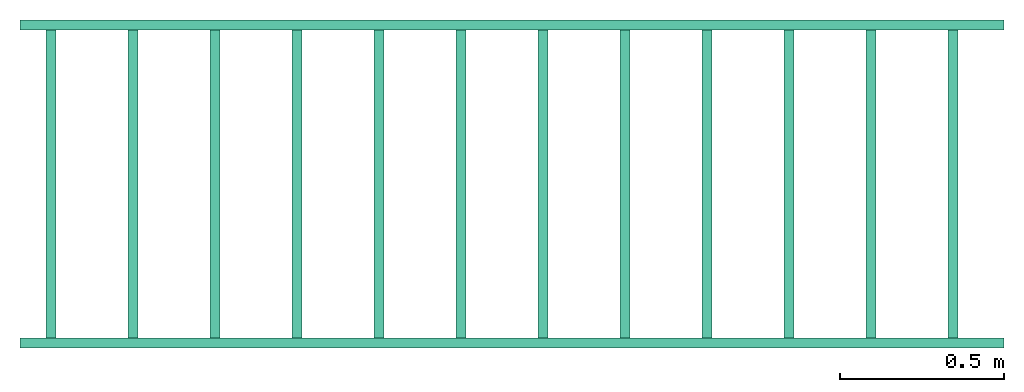
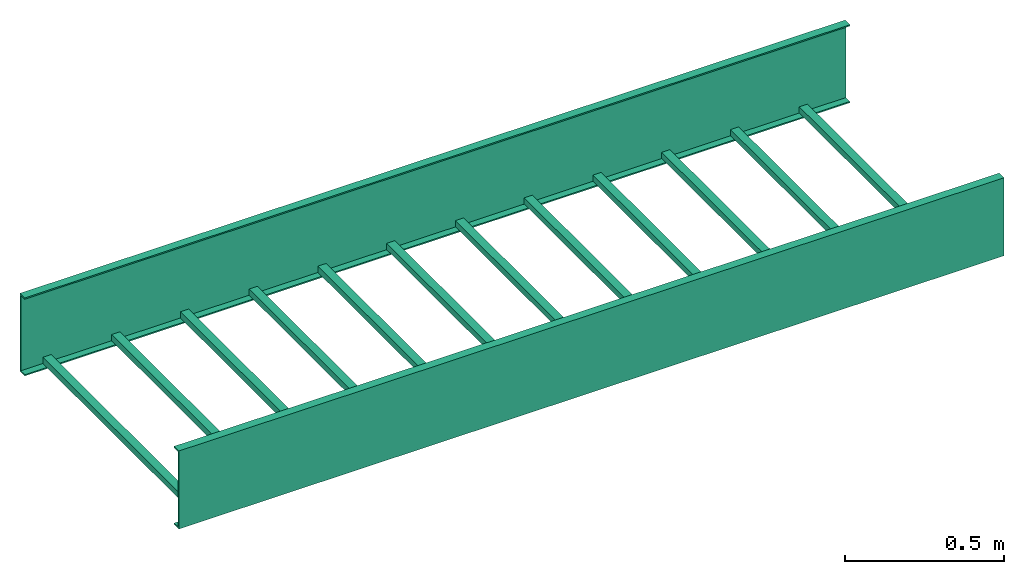
# One storey: 3 cable carrier segments.
"""IFC4X3_ADD2 building model written with IfcOpenShell, lengths in metres."""

from ifc_helpers import new_model, entity, si_unit, converted_unit, frame, origin_with_axes, origin_2d_with_axis, place, context, subcontext, project, spatial, indexed_curve, c_section, outline, composite_profile, extrude, source, transform, mapped, material, material_profile, profile_set, profile_usage, type_object, type_shapes, element, save


model = new_model("IFC4X3_ADD2")

# Units and contexts
model_context = context("Model", 3, precision=1e-05, world=origin_with_axes())
plan_context = context("Plan", 2, precision=1e-05, world=origin_2d_with_axis())
body_context = subcontext(model_context, "Body", "Model", "MODEL_VIEW")
ifc_project = project(units=[converted_unit("PLANEANGLEUNIT", "degree", entity("IfcReal", 0.0174532925199433), si_unit("PLANEANGLEUNIT", "RADIAN"), dimensions=[0, 0, 0, 0, 0, 0, 0]), si_unit("AREAUNIT", "SQUARE_METRE"), si_unit("VOLUMEUNIT", "CUBIC_METRE"), si_unit("LENGTHUNIT", "METRE")], contexts=[model_context, plan_context])

# Site, building, storey
site_placement = place(None, origin_with_axes())
site = spatial("IfcSite", under=ifc_project, at=site_placement)
building_placement = place(site_placement, origin_with_axes())
building = spatial("IfcBuilding", under=site, at=building_placement, Name="Building")
storey_placement = place(building_placement, origin_with_axes())
storey = spatial("IfcBuildingStorey", under=building, at=storey_placement, Name="Storey")

# Cable carrier segments
cable_carrier_segment_type_1 = type_object("IfcCableCarrierSegmentType", PredefinedType="CABLELADDERSEGMENT")
shared_shape = source(origin_with_axes(), body_context, "Body", "SweptSolid", [
    extrude(composite_profile([outline(indexed_curve([(-2.75, 1.07604632940562e-13), (-2.72000002861023, 1.07604632940562e-13), (-2.72000002861023, 0.0240000039339066), (-2.75, 0.0240000039339066), (-2.75, 1.07604632940562e-13)])), outline(indexed_curve([(-2.5, 9.77424928104084e-14), (-2.47000002861023, 9.77424928104084e-14), (-2.47000002861023, 0.0240000039339066), (-2.5, 0.0240000039339066), (-2.5, 9.77424928104084e-14)])), outline(indexed_curve([(-2.25, 8.7880352680255e-14), (-2.22000002861023, 8.7880352680255e-14), (-2.22000002861023, 0.0240000039339066), (-2.25, 0.0240000039339066), (-2.25, 8.7880352680255e-14)])), outline(indexed_curve([(-2.0, 7.80182125501017e-14), (-1.97000002861023, 7.80182125501017e-14), (-1.97000002861023, 0.0240000039339066), (-2.0, 0.0240000039339066), (-2.0, 7.80182125501017e-14)])), outline(indexed_curve([(-1.75, 6.81560724199483e-14), (-1.72000002861023, 6.81560724199483e-14), (-1.72000002861023, 0.0240000039339066), (-1.75, 0.0240000039339066), (-1.75, 6.81560724199483e-14)])), outline(indexed_curve([(-1.5, 5.82939322897949e-14), (-1.47000002861023, 5.82939322897949e-14), (-1.47000002861023, 0.0240000039339066), (-1.5, 0.0240000039339066), (-1.5, 5.82939322897949e-14)])), outline(indexed_curve([(-1.25, 4.84317887715097e-14), (-1.22000002861023, 4.84317887715097e-14), (-1.22000002861023, 0.0240000039339066), (-1.25, 0.0240000039339066), (-1.25, 4.84317887715097e-14)])), outline(indexed_curve([(-1.0, 3.85696486413564e-14), (-0.970000028610229, 3.85696486413564e-14), (-0.970000028610229, 0.0240000039339066), (-1.0, 0.0240000039339066), (-1.0, 3.85696486413564e-14)])), outline(indexed_curve([(-0.75, 2.8707508511203e-14), (-0.720000028610229, 2.8707508511203e-14), (-0.720000028610229, 0.0240000039339066), (-0.75, 0.0240000039339066), (-0.75, 2.8707508511203e-14)])), outline(indexed_curve([(-0.5, 1.88453683810496e-14), (-0.469999998807907, 1.88453683810496e-14), (-0.469999998807907, 0.0240000039339066), (-0.5, 0.0240000039339066), (-0.5, 1.88453683810496e-14)])), outline(indexed_curve([(-0.25, 8.98322909792916e-15), (-0.219999998807907, 8.98322909792916e-15), (-0.219999998807907, 0.0240000039339066), (-0.25, 0.0240000039339066), (-0.25, 8.98322909792916e-15)])), outline(indexed_curve([(0.0, 0.0), (0.0299999993294477, 0.0), (0.0299999993294477, 0.0240000039339066), (0.0, 0.0240000039339066), (0.0, 0.0)]))]), frame((0.110000133514404, 0.00500005390495062, 0.00499999895691872), z_axis=(-3.25841369885893e-07, 1.0, 7.54979012640433e-08), x_axis=(-1.0, -3.25841369885893e-07, 0.0)), (0.0, 0.0, 1.0), 0.990000009536743),
])
type_shapes(cable_carrier_segment_type_1, [shared_shape])
cable_carrier_segment_1_placement = place(storey_placement, origin_with_axes())
element("IfcCableCarrierSegment", 1, at=cable_carrier_segment_1_placement, inside=storey, type_object=cable_carrier_segment_type_1, Name="CableCarrierSegment", context=body_context, shape_type="MappedRepresentation", body=[
    mapped(shared_shape, transform((0.0, 0.0, 0.0), x_axis=(1.0, 0.0, 0.0), y_axis=(0.0, 1.0, 0.0), z_axis=(0.0, 0.0, 1.0), scale=1.0)),
])
ifc_material = material()
ifc_material_profile = material_profile(ifc_material, c_section(Depth=0.300000011920929, Width=0.0299999993294477, WallThickness=0.00499999988824129, Girth=0.00499999988824129))
ifc_profile_set = profile_set([ifc_material_profile])
ifc_profile_usage_1 = profile_usage(ifc_profile_set, cardinal=3)
cable_carrier_segment_type_2 = type_object("IfcCableCarrierSegmentType", Name="side", PredefinedType="CABLELADDERSEGMENT", material=ifc_profile_set)
cable_carrier_segment_2_placement = place(storey_placement, frame((0.0, 0.0, 0.0), z_axis=(0.999999999999998, 4.37113882867378e-08, -4.37113882867378e-08), x_axis=(-4.37113882867379e-08, 0.999999999999999, 0.0)))
element("IfcCableCarrierSegment", 2, at=cable_carrier_segment_2_placement, inside=storey, type_object=cable_carrier_segment_type_2, material=ifc_profile_usage_1, Name="CableCarrierSegment", context=body_context, shape_type="SweptSolid", body=[
    extrude(c_section(Depth=0.300000011920929, Width=0.0299999993294477, WallThickness=0.00499999988824129, Girth=0.00499999988824129), frame((0.0149999996647239, 0.150000005960464, 0.0), z_axis=(2.21371740966953e-09, -2.38376675124746e-07, 0.999999995530419), x_axis=(0.999999999999997, -1.18065856011958e-07, -2.21374408225966e-09)), (0.0, 0.0, 1.0), 3.00000031789143),
])
ifc_profile_usage_2 = profile_usage(ifc_profile_set, cardinal=3)
cable_carrier_segment_3_placement = place(storey_placement, frame((3.00000023841858, 1.0, -1.31134186176496e-07), z_axis=(-0.999999999999998, 4.37113882867378e-08, -4.37113882867378e-08), x_axis=(-4.37113882867379e-08, -0.999999999999999, 0.0)))
element("IfcCableCarrierSegment", 3, at=cable_carrier_segment_3_placement, inside=storey, type_object=cable_carrier_segment_type_2, material=ifc_profile_usage_2, Name="CableCarrierSegment", context=body_context, shape_type="SweptSolid", body=[
    extrude(c_section(Depth=0.300000011920929, Width=0.0299999993294477, WallThickness=0.00499999988824129, Girth=0.00499999988824129), frame((0.0149999996647239, 0.150000005960464, 0.0), z_axis=(2.21371740966953e-09, -2.38376675124746e-07, 0.999999995530419), x_axis=(0.999999999999997, -1.18065856011958e-07, -2.21374408225966e-09)), (0.0, 0.0, 1.0), 3.00000031789143),
])

save(model, "model.ifc")
